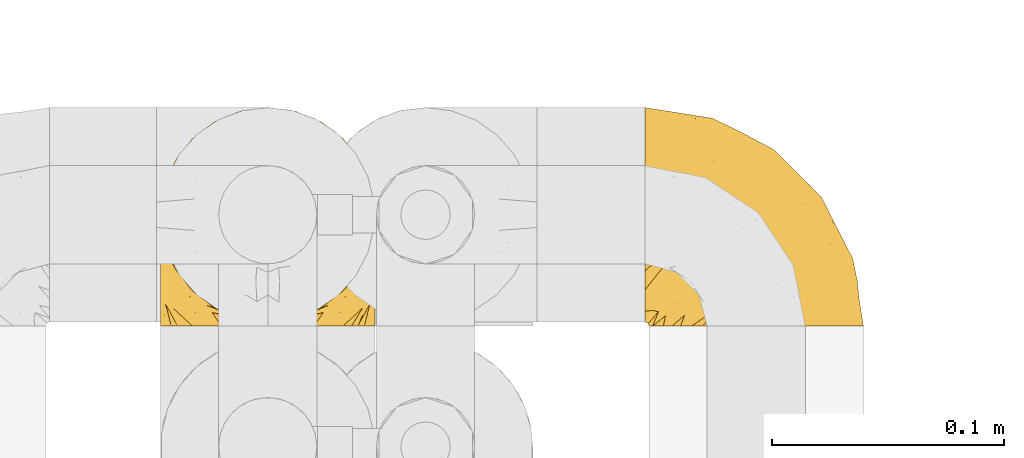
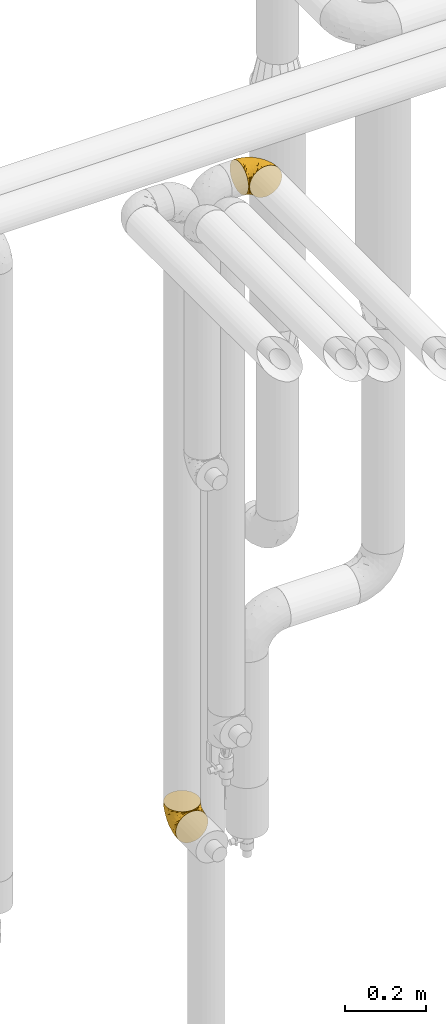
# One storey, part 312 of 827: 2 coverings.
"""IFC2X3 building model written with IfcOpenShell, lengths in millimetres."""

from ifc_helpers import new_model, entity, si_unit, converted_unit, derived_unit, direction, frame, origin, place, context, subcontext, project, spatial, faceted_brep, element, save


model = new_model("IFC2X3")

# Units and contexts
model_context = context("Model", 3, precision=0.01, world=origin(), true_north=direction((6.12303176911189e-17, 1.0)))
body_context = subcontext(model_context, "Body", "Model", "MODEL_VIEW")
ifc_project = project(units=[si_unit("LENGTHUNIT", "METRE", prefix="MILLI"), si_unit("AREAUNIT", "SQUARE_METRE"), si_unit("VOLUMEUNIT", "CUBIC_METRE"), converted_unit("PLANEANGLEUNIT", "DEGREE", entity("IfcRatioMeasure", 0.0174532925199433), si_unit("PLANEANGLEUNIT", "RADIAN"), dimensions=[0, 0, 0, 0, 0, 0, 0]), si_unit("MASSUNIT", "GRAM", prefix="KILO"), derived_unit("MASSDENSITYUNIT", [(si_unit("MASSUNIT", "GRAM", prefix="KILO"), 1), (si_unit("LENGTHUNIT", "METRE"), -3)]), derived_unit("MOMENTOFINERTIAUNIT", [(si_unit("LENGTHUNIT", "METRE"), 4)]), si_unit("TIMEUNIT", "SECOND"), si_unit("FREQUENCYUNIT", "HERTZ"), si_unit("THERMODYNAMICTEMPERATUREUNIT", "DEGREE_CELSIUS"), derived_unit("THERMALTRANSMITTANCEUNIT", [(si_unit("MASSUNIT", "GRAM", prefix="KILO"), 1), (si_unit("THERMODYNAMICTEMPERATUREUNIT", "KELVIN"), -1), (si_unit("TIMEUNIT", "SECOND"), -3)]), derived_unit("VOLUMETRICFLOWRATEUNIT", [(si_unit("LENGTHUNIT", "METRE"), 3), (si_unit("TIMEUNIT", "SECOND"), -1)]), derived_unit("MASSFLOWRATEUNIT", [(si_unit("MASSUNIT", "GRAM", prefix="KILO"), 1), (si_unit("TIMEUNIT", "SECOND"), -1)]), derived_unit("ROTATIONALFREQUENCYUNIT", [(si_unit("TIMEUNIT", "SECOND"), -1)]), si_unit("ELECTRICCURRENTUNIT", "AMPERE"), si_unit("ELECTRICVOLTAGEUNIT", "VOLT"), si_unit("POWERUNIT", "WATT"), si_unit("FORCEUNIT", "NEWTON", prefix="KILO"), si_unit("ILLUMINANCEUNIT", "LUX"), si_unit("LUMINOUSFLUXUNIT", "LUMEN"), si_unit("LUMINOUSINTENSITYUNIT", "CANDELA"), derived_unit("USERDEFINED", [(si_unit("MASSUNIT", "GRAM", prefix="KILO"), -1), (si_unit("LENGTHUNIT", "METRE"), -2), (si_unit("TIMEUNIT", "SECOND"), 3), (si_unit("LUMINOUSFLUXUNIT", "LUMEN"), 1)]), derived_unit("LINEARVELOCITYUNIT", [(si_unit("LENGTHUNIT", "METRE"), 1), (si_unit("TIMEUNIT", "SECOND"), -1)]), si_unit("PRESSUREUNIT", "PASCAL"), derived_unit("USERDEFINED", [(si_unit("LENGTHUNIT", "METRE"), -2), (si_unit("MASSUNIT", "GRAM", prefix="KILO"), 1), (si_unit("TIMEUNIT", "SECOND"), -2)]), derived_unit("LINEARFORCEUNIT", [(si_unit("MASSUNIT", "GRAM", prefix="KILO"), 1), (si_unit("LENGTHUNIT", "METRE"), 1), (si_unit("TIMEUNIT", "SECOND"), -2), (si_unit("LENGTHUNIT", "METRE"), -1)]), derived_unit("PLANARFORCEUNIT", [(si_unit("MASSUNIT", "GRAM", prefix="KILO"), 1), (si_unit("LENGTHUNIT", "METRE"), 1), (si_unit("TIMEUNIT", "SECOND"), -2), (si_unit("LENGTHUNIT", "METRE"), -2)])], contexts=[model_context])

# Site, building, storey
site_placement = place(None, origin())
site = spatial("IfcSite", under=ifc_project, at=site_placement, CompositionType="ELEMENT")
building_placement = place(site_placement, origin())
building = spatial("IfcBuilding", under=site, at=building_placement, CompositionType="ELEMENT")
storey_placement = place(building_placement, frame((0.0, 0.0, 28200.0)))
storey = spatial("IfcBuildingStorey", under=building, at=storey_placement, Name="08", CompositionType="ELEMENT", Elevation=28200.0)

# Coverings
covering_1_placement = place(storey_placement, frame((30818.01, 18391.61, 2952.2)))
element("IfcCovering", 1, at=covering_1_placement, inside=storey, Name=":ADSK_", ObjectType=":ADSK_", PredefinedType="INSULATION", context=body_context, shape_type="Brep", body=[
    faceted_brep([(1.6, 59.88, 92.84), (1.6, 69.65, 89.42), (1.6, 78.41, 83.91), (1.6, 85.72, 76.59), (1.6, 91.22, 67.83), (1.6, 94.64, 58.07), (1.6, 95.8, 47.8), (1.6, 94.64, 37.51), (1.6, 91.22, 27.74), (1.6, 85.71, 18.98), (1.6, 78.39, 11.67), (1.6, 69.63, 6.17), (1.6, 59.87, 2.75), (1.6, 49.6, 1.6), (1.6, 45.45, 2.06), (1.6, 42.38, 2.41), (1.6, 39.31, 2.75), (1.6, 34.43, 4.46), (1.6, 29.54, 6.17), (1.6, 25.16, 8.93), (1.6, 20.78, 11.68), (1.6, 17.13, 15.34), (1.6, 13.47, 19.0), (1.6, 7.97, 27.76), (1.6, 6.26, 32.64), (1.6, 4.55, 37.52), (1.6, 3.4, 47.8), (1.6, 4.55, 58.08), (1.6, 6.26, 62.96), (1.6, 7.97, 67.85), (1.6, 13.48, 76.61), (1.6, 17.14, 80.26), (1.6, 20.8, 83.92), (1.6, 25.18, 86.67), (1.6, 29.56, 89.42), (1.6, 34.44, 91.13), (1.6, 39.32, 92.84), (1.6, 42.39, 93.18), (1.6, 45.45, 93.53), (1.6, 49.6, 94.0), (3.4, 1.6, 47.8), (4.97, 1.6, 35.84), (9.58, 1.6, 24.7), (13.26, 1.6, 19.91), (16.93, 1.6, 15.13), (21.71, 1.6, 11.46), (26.5, 1.6, 7.78), (32.07, 1.6, 5.48), (37.64, 1.6, 3.17), (41.25, 1.6, 2.69), (43.34, 1.6, 2.42), (45.42, 1.6, 2.14), (49.6, 1.6, 1.6), (61.55, 1.6, 3.17), (72.7, 1.6, 7.78), (82.26, 1.6, 15.13), (89.61, 1.6, 24.7), (94.22, 1.6, 35.84), (95.8, 1.6, 47.8), (94.22, 1.6, 59.75), (89.61, 1.6, 70.9), (82.26, 1.6, 80.46), (72.7, 1.6, 87.81), (61.55, 1.6, 92.42), (49.6, 1.6, 94.0), (45.42, 1.6, 93.45), (41.25, 1.6, 92.9), (37.64, 1.6, 92.42), (32.07, 1.6, 90.11), (26.5, 1.6, 87.81), (21.71, 1.6, 84.13), (16.93, 1.6, 80.46), (13.26, 1.6, 75.68), (9.58, 1.6, 70.9), (4.97, 1.6, 59.75), (81.55, 36.81, 71.98), (90.4, 23.28, 63.6), (83.0, 45.8, 59.72), (91.18, 30.7, 47.8), (93.13, 21.2, 55.16), (94.0, 12.96, 47.8), (66.19, 66.19, 63.76), (70.92, 54.51, 72.22), (85.95, 17.98, 74.18), (49.74, 36.69, 92.52), (35.54, 35.54, 94.0), (38.14, 31.64, 94.0), (40.74, 27.75, 94.0), (43.34, 23.86, 94.0), (45.94, 19.96, 94.0), (77.59, 22.8, 82.14), (71.17, 42.67, 80.34), (65.81, 33.21, 87.52), (59.03, 59.45, 79.59), (45.85, 71.5, 78.25), (45.79, 62.66, 85.01), (41.42, 54.5, 90.25), (34.51, 47.57, 93.2), (56.04, 48.81, 87.23), (15.15, 74.98, 85.55), (56.51, 18.7, 93.0), (68.39, 15.75, 89.31), (23.33, 91.17, 61.31), (42.86, 85.28, 56.86), (39.42, 82.58, 68.34), (53.58, 75.78, 65.71), (59.17, 74.98, 56.99), (59.06, 67.27, 72.15), (22.63, 87.38, 70.34), (20.55, 82.04, 78.36), (12.96, 94.0, 47.8), (56.96, 77.8, 47.8), (67.38, 67.38, 47.8), (18.72, 56.2, 93.06), (5.33, 48.85, 94.0), (9.07, 48.11, 94.0), (11.79, 47.57, 94.0), (14.51, 47.03, 94.0), (17.24, 46.48, 94.0), (19.96, 45.94, 94.0), (21.03, 65.78, 89.88), (46.48, 17.24, 94.0), (47.03, 14.51, 94.0), (47.57, 11.79, 94.0), (48.11, 9.07, 94.0), (48.48, 7.2, 94.0), (48.85, 5.33, 94.0), (30.7, 91.18, 47.8), (23.86, 43.34, 94.0), (27.75, 40.74, 94.0), (31.64, 38.14, 94.0), (31.26, 72.73, 83.7), (77.8, 56.96, 47.8), (72.75, 62.23, 55.9), (43.83, 84.49, 47.8), (84.49, 43.83, 47.8), (14.58, 12.05, 81.75), (16.17, 18.95, 86.43), (10.82, 13.02, 79.8), (4.64, 8.34, 69.84), (7.71, 14.63, 79.5), (25.13, 11.09, 88.08), (32.66, 13.66, 91.6), (34.94, 20.08, 92.93), (36.76, 9.61, 92.43), (40.48, 9.48, 93.24), (39.25, 16.1, 93.36), (3.69, 3.42, 57.25), (13.99, 26.63, 89.41), (21.85, 33.72, 92.89), (17.93, 34.77, 92.66), (15.11, 6.75, 79.58), (21.14, 13.31, 86.51), (7.21, 19.94, 83.91), (9.47, 27.05, 88.76), (10.45, 6.04, 73.94), (32.27, 8.67, 90.94), (25.68, 26.11, 91.94), (22.18, 29.3, 91.98), (18.79, 6.32, 82.79), (10.12, 39.92, 93.16), (11.29, 34.4, 91.89), (2.87, 2.87, 47.8), (31.16, 20.92, 92.22), (12.7, 21.11, 86.29), (6.31, 27.43, 88.56), (25.62, 7.54, 87.72), (21.18, 18.45, 88.33), (28.81, 23.88, 92.18), (7.45, 7.77, 71.78), (21.14, 13.3, 9.09), (25.13, 11.09, 7.51), (18.79, 6.33, 12.8), (48.11, 9.07, 1.6), (48.85, 5.33, 1.6), (47.03, 14.51, 1.6), (47.57, 11.79, 1.6), (3.69, 3.42, 38.35), (7.44, 7.76, 23.84), (14.51, 47.03, 1.6), (11.79, 47.57, 1.6), (5.33, 48.85, 1.6), (9.07, 48.11, 1.6), (7.71, 14.62, 16.1), (9.47, 27.03, 6.84), (34.94, 20.08, 2.66), (31.16, 20.92, 3.37), (40.74, 27.75, 1.6), (38.14, 31.64, 1.6), (36.76, 9.61, 3.16), (40.48, 9.48, 2.35), (4.63, 8.33, 25.77), (15.11, 6.74, 16.02), (14.58, 12.04, 13.85), (43.34, 23.86, 1.6), (45.94, 19.96, 1.6), (39.25, 16.1, 2.23), (7.21, 19.93, 11.69), (12.69, 21.1, 9.31), (10.14, 39.92, 2.43), (21.81, 33.68, 2.71), (22.19, 29.28, 3.61), (14.0, 26.62, 6.18), (25.69, 26.08, 3.66), (16.17, 18.93, 9.17), (6.66, 27.87, 6.77), (17.92, 34.75, 2.93), (10.45, 6.04, 21.66), (31.64, 38.14, 1.6), (10.64, 12.79, 16.09), (11.31, 34.41, 3.7), (19.96, 45.94, 1.6), (23.86, 43.34, 1.6), (27.75, 40.74, 1.6), (32.66, 13.66, 3.99), (46.48, 17.24, 1.6), (32.27, 8.67, 4.65), (35.54, 35.54, 1.6), (28.77, 23.83, 3.43), (21.17, 18.43, 7.27), (23.36, 6.03, 9.46), (17.24, 46.48, 1.6), (47.58, 34.52, 2.4), (93.13, 21.2, 40.43), (77.44, 23.82, 13.57), (66.78, 41.32, 11.3), (71.68, 47.62, 18.65), (74.96, 52.66, 27.26), (81.55, 36.81, 23.61), (36.7, 49.75, 3.07), (56.9, 19.07, 2.69), (83.0, 45.8, 35.87), (90.4, 23.28, 31.99), (67.83, 21.35, 6.71), (85.95, 17.98, 21.41), (39.41, 82.57, 27.24), (23.33, 91.17, 34.26), (42.87, 85.27, 38.73), (53.92, 73.89, 26.97), (66.19, 66.19, 31.83), (64.12, 62.43, 23.4), (33.13, 63.53, 6.91), (23.1, 58.45, 3.4), (16.98, 67.16, 5.84), (55.72, 76.72, 35.73), (72.75, 62.22, 39.69), (23.77, 81.54, 17.6), (18.41, 74.8, 10.38), (43.7, 75.83, 20.6), (54.53, 41.45, 5.36), (17.73, 88.2, 24.84), (38.98, 71.6, 13.87), (50.28, 56.23, 9.06), (59.02, 59.44, 15.99)], [[[0, 1, 2, 3, 4, 5, 6, 7, 8, 9, 10, 11, 12, 13, 14, 15, 16, 17, 18, 19, 20, 21, 22, 23, 24, 25, 26, 27, 28, 29, 30, 31, 32, 33, 34, 35, 36, 37, 38, 39]], [[40, 41, 42, 43, 44, 45, 46, 47, 48, 49, 50, 51, 52, 53, 54, 55, 56, 57, 58, 59, 60, 61, 62, 63, 64, 65, 66, 67, 68, 69, 70, 71, 72, 73, 74]], [[75, 76, 77]], [[78, 79, 80]], [[77, 81, 82]], [[76, 75, 83]], [[84, 85, 86, 87, 88, 89]], [[90, 91, 92]], [[76, 60, 59]], [[93, 94, 95]], [[90, 62, 61]], [[83, 61, 60]], [[96, 97, 84]], [[98, 93, 95]], [[2, 1, 99]], [[100, 84, 89]], [[62, 101, 63]], [[4, 102, 5]], [[92, 84, 100]], [[103, 102, 104]], [[103, 105, 106]], [[93, 107, 94]], [[3, 108, 4]], [[92, 101, 90]], [[108, 3, 109]], [[102, 110, 5]], [[93, 82, 107]], [[102, 108, 104]], [[111, 106, 112]], [[109, 2, 99]], [[113, 39, 114, 115, 116, 117, 118, 119]], [[120, 0, 113]], [[100, 89, 121, 122, 123, 124, 125, 126, 64]], [[127, 102, 103]], [[97, 119, 128, 129, 130, 85]], [[99, 120, 131]], [[132, 133, 77]], [[59, 80, 79]], [[3, 2, 109]], [[98, 84, 92]], [[94, 109, 131]], [[120, 1, 0]], [[93, 91, 82]], [[104, 94, 105]], [[97, 113, 119]], [[95, 120, 96]], [[83, 90, 61]], [[91, 93, 98]], [[64, 63, 100]], [[100, 63, 101]], [[77, 76, 79]], [[133, 106, 81]], [[84, 97, 85]], [[113, 96, 120]], [[113, 97, 96]], [[39, 113, 0]], [[110, 102, 127]], [[110, 6, 5]], [[103, 111, 134, 127]], [[90, 75, 91]], [[82, 81, 107]], [[91, 75, 82]], [[77, 82, 75]], [[76, 83, 60]], [[90, 83, 75]], [[105, 107, 81]], [[94, 131, 95]], [[105, 94, 107]], [[109, 94, 104]], [[120, 95, 131]], [[98, 95, 96]], [[84, 98, 96]], [[98, 92, 91]], [[106, 105, 81]], [[103, 104, 105]], [[133, 132, 112]], [[103, 106, 111]], [[77, 78, 135, 132]], [[106, 133, 112]], [[77, 133, 81]], [[120, 99, 1]], [[109, 99, 131]], [[59, 58, 80]], [[59, 79, 76]], [[90, 101, 62]], [[100, 101, 92]], [[4, 108, 102]], [[109, 104, 108]], [[78, 77, 79]], [[136, 137, 138]], [[29, 139, 140]], [[141, 142, 143]], [[144, 145, 121]], [[146, 89, 88]], [[147, 139, 27]], [[148, 149, 150]], [[136, 151, 152]], [[147, 40, 74]], [[26, 147, 27]], [[153, 148, 154]], [[35, 116, 36]], [[73, 151, 155]], [[114, 39, 38, 37, 36, 116, 115]], [[146, 156, 144]], [[157, 85, 130]], [[158, 149, 148]], [[151, 159, 152]], [[117, 35, 160]], [[31, 153, 154]], [[155, 74, 73]], [[161, 128, 119]], [[66, 65, 64, 126, 125, 124, 123, 122, 67]], [[162, 147, 26]], [[29, 140, 30]], [[149, 129, 150]], [[139, 29, 28, 27]], [[68, 144, 69]], [[129, 128, 150]], [[163, 87, 86]], [[130, 129, 149]], [[122, 145, 67]], [[153, 164, 148]], [[161, 119, 160]], [[165, 32, 154]], [[150, 154, 148]], [[128, 161, 150]], [[32, 165, 33]], [[145, 144, 68]], [[89, 146, 144]], [[87, 163, 143]], [[166, 156, 142]], [[88, 87, 143]], [[161, 154, 150]], [[154, 32, 31]], [[31, 30, 153]], [[30, 140, 153]], [[164, 153, 140]], [[140, 137, 164]], [[158, 148, 164]], [[157, 130, 158]], [[164, 137, 158]], [[158, 137, 157]], [[167, 137, 136]], [[168, 85, 157]], [[152, 168, 167]], [[167, 168, 157]], [[163, 152, 141]], [[151, 73, 72]], [[159, 72, 71]], [[88, 142, 146]], [[144, 156, 69]], [[146, 142, 156]], [[70, 166, 71]], [[142, 141, 166]], [[70, 69, 156]], [[141, 159, 71]], [[167, 136, 152]], [[138, 137, 140]], [[155, 136, 169]], [[136, 155, 151]], [[74, 155, 169]], [[152, 159, 141]], [[151, 72, 159]], [[168, 152, 163]], [[137, 167, 157]], [[163, 86, 168]], [[85, 168, 86]], [[116, 35, 117]], [[130, 149, 158]], [[67, 145, 68]], [[121, 89, 144]], [[145, 122, 121]], [[40, 147, 162]], [[169, 147, 74]], [[160, 35, 34]], [[161, 160, 34]], [[160, 119, 118, 117]], [[139, 147, 169]], [[139, 169, 138]], [[161, 34, 33]], [[141, 143, 163]], [[88, 143, 142]], [[71, 166, 141]], [[156, 166, 70]], [[139, 138, 140]], [[169, 136, 138]], [[154, 161, 165]], [[161, 33, 165]], [[170, 171, 172]], [[173, 174, 52, 51, 50, 49, 48, 175, 176]], [[177, 178, 41]], [[179, 17, 180]], [[14, 13, 181, 182, 180, 16, 15]], [[183, 23, 22]], [[21, 20, 184]], [[185, 186, 187]], [[186, 188, 187]], [[43, 172, 44]], [[189, 190, 47]], [[25, 24, 23, 191]], [[170, 192, 193]], [[40, 162, 177]], [[194, 195, 196]], [[26, 25, 177]], [[197, 198, 183]], [[199, 17, 179]], [[47, 46, 189]], [[200, 201, 202]], [[201, 203, 204]], [[205, 206, 184]], [[207, 41, 178]], [[18, 17, 199]], [[16, 180, 17]], [[202, 201, 198]], [[208, 201, 200]], [[162, 26, 177]], [[48, 47, 190]], [[196, 195, 189]], [[197, 184, 202]], [[204, 193, 209]], [[210, 211, 212]], [[206, 212, 213]], [[205, 19, 210]], [[184, 206, 202]], [[210, 212, 206]], [[185, 194, 214]], [[189, 215, 190]], [[216, 45, 214]], [[186, 171, 170]], [[189, 216, 196]], [[197, 22, 21]], [[194, 185, 187]], [[197, 183, 22]], [[184, 197, 21]], [[197, 202, 198]], [[206, 200, 202]], [[204, 183, 198]], [[201, 208, 203]], [[203, 208, 217]], [[204, 198, 201]], [[217, 188, 218]], [[193, 219, 170]], [[171, 186, 185]], [[170, 218, 186]], [[170, 219, 218]], [[42, 207, 192]], [[171, 220, 172]], [[216, 189, 46]], [[214, 194, 196]], [[44, 220, 45]], [[214, 196, 216]], [[216, 46, 45]], [[214, 45, 220]], [[192, 43, 42]], [[204, 203, 219]], [[207, 193, 192]], [[209, 193, 178]], [[41, 207, 42]], [[193, 207, 178]], [[43, 192, 172]], [[170, 172, 192]], [[204, 219, 193]], [[219, 203, 218]], [[217, 218, 203]], [[188, 186, 218]], [[206, 213, 200]], [[208, 200, 213]], [[199, 210, 18]], [[215, 189, 195]], [[215, 175, 190]], [[175, 48, 190]], [[199, 179, 221, 211]], [[210, 199, 211]], [[25, 191, 177]], [[40, 177, 41]], [[183, 209, 191]], [[183, 191, 23]], [[191, 178, 177]], [[205, 20, 19]], [[19, 18, 210]], [[171, 185, 214]], [[172, 220, 44]], [[214, 220, 171]], [[191, 209, 178]], [[204, 209, 183]], [[206, 205, 210]], [[20, 205, 184]], [[222, 195, 194, 187, 188, 217]], [[57, 223, 80]], [[224, 225, 226]], [[226, 227, 228]], [[229, 217, 208, 213, 212, 211]], [[230, 52, 174, 173, 176, 175, 215, 195]], [[231, 232, 228]], [[231, 78, 223]], [[223, 57, 232]], [[224, 233, 225]], [[233, 54, 53]], [[234, 232, 56]], [[56, 55, 234]], [[234, 224, 228]], [[235, 236, 237]], [[224, 55, 54]], [[238, 239, 240]], [[52, 230, 53]], [[241, 242, 243]], [[239, 244, 245]], [[13, 12, 242]], [[236, 8, 7]], [[9, 246, 10]], [[10, 247, 11]], [[238, 248, 235]], [[222, 229, 249]], [[242, 211, 221, 179, 180, 182, 181, 13]], [[233, 53, 230]], [[111, 112, 244]], [[250, 8, 236]], [[247, 251, 241]], [[8, 250, 9]], [[127, 236, 110]], [[249, 229, 252]], [[247, 10, 246]], [[235, 246, 250]], [[236, 7, 110]], [[235, 244, 238]], [[237, 236, 127]], [[243, 11, 247]], [[252, 229, 241]], [[56, 232, 57]], [[222, 230, 195]], [[225, 249, 252]], [[249, 233, 230]], [[54, 233, 224]], [[231, 228, 227]], [[245, 132, 231]], [[249, 225, 233]], [[226, 225, 253]], [[235, 250, 236]], [[246, 9, 250]], [[251, 247, 246]], [[243, 247, 241]], [[248, 246, 235]], [[252, 251, 253]], [[229, 222, 217]], [[230, 222, 249]], [[7, 6, 110]], [[237, 127, 134, 111]], [[238, 244, 239]], [[224, 234, 55]], [[232, 234, 228]], [[242, 241, 229]], [[12, 11, 243]], [[211, 242, 229]], [[12, 243, 242]], [[80, 223, 78]], [[80, 58, 57]], [[231, 223, 232]], [[227, 240, 239]], [[224, 226, 228]], [[240, 226, 253]], [[227, 239, 245]], [[226, 240, 227]], [[251, 248, 253]], [[240, 253, 248]], [[244, 235, 237]], [[237, 111, 244]], [[132, 245, 112]], [[112, 245, 244]], [[135, 78, 231, 132]], [[227, 245, 231]], [[248, 238, 240]], [[246, 248, 251]], [[251, 252, 241]], [[225, 252, 253]]]),
])
covering_2_placement = place(storey_placement, frame((30609.25, 18391.61, 1082.65)))
element("IfcCovering", 2, at=covering_2_placement, inside=storey, Name=":ADSK_", ObjectType=":ADSK_", PredefinedType="INSULATION", context=body_context, shape_type="Brep", body=[
    faceted_brep([(11.68, 1.6, 18.98), (19.0, 1.6, 11.67), (27.76, 1.6, 6.17), (37.52, 1.6, 2.75), (47.8, 1.6, 1.6), (58.08, 1.6, 2.75), (67.85, 1.6, 6.17), (76.61, 1.6, 11.68), (83.92, 1.6, 19.0), (89.42, 1.6, 27.76), (92.84, 1.6, 37.52), (94.0, 1.6, 47.8), (93.53, 1.6, 51.94), (93.18, 1.6, 55.01), (92.84, 1.6, 58.08), (91.13, 1.6, 62.96), (89.42, 1.6, 67.85), (86.66, 1.6, 72.23), (83.91, 1.6, 76.61), (80.25, 1.6, 80.26), (76.59, 1.6, 83.92), (67.83, 1.6, 89.42), (62.95, 1.6, 91.13), (58.07, 1.6, 92.84), (47.8, 1.6, 94.0), (37.51, 1.6, 92.84), (32.63, 1.6, 91.13), (27.74, 1.6, 89.42), (18.98, 1.6, 83.91), (15.33, 1.6, 80.25), (11.67, 1.6, 76.59), (8.92, 1.6, 72.21), (6.17, 1.6, 67.83), (4.46, 1.6, 62.95), (2.75, 1.6, 58.07), (2.41, 1.6, 55.0), (2.06, 1.6, 51.94), (1.6, 1.6, 47.8), (2.75, 1.6, 37.51), (6.17, 1.6, 27.74), (47.8, 3.4, 95.8), (59.75, 4.97, 95.8), (70.9, 9.58, 95.8), (75.68, 13.26, 95.8), (80.46, 16.93, 95.8), (84.13, 21.71, 95.8), (87.81, 26.5, 95.8), (90.11, 32.07, 95.8), (92.42, 37.64, 95.8), (92.9, 41.25, 95.8), (93.17, 43.34, 95.8), (93.45, 45.42, 95.8), (94.0, 49.6, 95.8), (92.42, 61.55, 95.8), (87.81, 72.7, 95.8), (80.46, 82.26, 95.8), (70.9, 89.61, 95.8), (59.75, 94.22, 95.8), (47.8, 95.8, 95.8), (35.84, 94.22, 95.8), (24.7, 89.61, 95.8), (15.13, 82.26, 95.8), (7.78, 72.7, 95.8), (3.17, 61.55, 95.8), (1.6, 49.6, 95.8), (2.14, 45.42, 95.8), (2.69, 41.25, 95.8), (3.17, 37.64, 95.8), (5.48, 32.07, 95.8), (7.78, 26.5, 95.8), (11.46, 21.71, 95.8), (15.13, 16.93, 95.8), (19.91, 13.26, 95.8), (24.7, 9.58, 95.8), (35.84, 4.97, 95.8), (23.61, 81.55, 60.58), (31.99, 90.4, 74.11), (35.87, 83.0, 51.59), (47.8, 91.18, 66.69), (40.43, 93.13, 76.19), (47.8, 94.0, 84.43), (31.83, 66.19, 31.2), (23.37, 70.92, 42.88), (21.41, 85.95, 79.41), (3.07, 49.74, 60.7), (1.6, 35.54, 61.85), (1.6, 38.14, 65.75), (1.6, 40.74, 69.64), (1.6, 43.34, 73.53), (1.6, 45.94, 77.43), (13.45, 77.59, 74.59), (15.25, 71.17, 54.72), (8.07, 65.81, 64.18), (16.0, 59.03, 37.94), (17.34, 45.85, 25.89), (10.58, 45.79, 34.73), (5.34, 41.42, 42.89), (2.39, 34.51, 49.83), (8.36, 56.04, 48.58), (10.04, 15.15, 22.41), (2.59, 56.51, 78.69), (6.28, 68.39, 81.64), (34.28, 23.33, 6.22), (38.73, 42.86, 12.11), (27.25, 39.42, 14.81), (29.88, 53.58, 21.61), (38.6, 59.17, 22.41), (23.44, 59.06, 30.12), (25.25, 22.63, 10.01), (17.23, 20.55, 15.36), (47.8, 12.96, 3.39), (47.8, 56.96, 19.59), (47.8, 67.38, 30.01), (2.53, 18.72, 41.19), (1.6, 5.33, 48.54), (1.6, 9.07, 49.28), (1.6, 11.79, 49.82), (1.6, 14.51, 50.37), (1.6, 17.24, 50.91), (1.6, 19.96, 51.45), (5.71, 21.03, 31.61), (1.6, 46.48, 80.15), (1.6, 47.03, 82.88), (1.6, 47.57, 85.6), (1.6, 48.11, 88.32), (1.6, 48.48, 90.19), (1.6, 48.85, 92.06), (47.8, 30.7, 6.21), (1.6, 23.86, 54.05), (1.6, 27.75, 56.65), (1.6, 31.64, 59.25), (11.89, 31.26, 24.66), (47.8, 77.8, 40.43), (39.69, 72.75, 35.17), (47.8, 43.83, 12.9), (47.8, 84.49, 53.56), (13.84, 14.58, 85.34), (9.16, 16.17, 78.44), (15.79, 10.82, 84.37), (25.75, 4.64, 89.05), (16.09, 7.71, 82.76), (7.51, 25.13, 86.31), (3.99, 32.66, 83.73), (2.66, 34.94, 77.31), (3.16, 36.76, 87.78), (2.35, 40.48, 87.91), (2.23, 39.25, 81.29), (38.35, 3.69, 93.97), (6.18, 13.99, 70.76), (2.7, 21.85, 63.67), (2.93, 17.93, 62.62), (16.01, 15.11, 90.64), (9.08, 21.14, 84.08), (11.68, 7.21, 77.45), (6.83, 9.47, 70.34), (4.65, 32.27, 88.72), (3.65, 25.68, 71.28), (3.61, 22.18, 68.09), (12.8, 18.79, 91.07), (2.43, 10.12, 57.47), (21.65, 10.45, 91.35), (3.7, 11.29, 62.99), (47.8, 2.87, 94.52), (3.37, 31.16, 76.47), (9.3, 12.7, 76.28), (7.03, 6.31, 69.96), (7.87, 25.62, 89.86), (7.26, 21.18, 78.94), (3.41, 28.81, 73.51), (23.81, 7.45, 89.62), (86.5, 21.14, 84.09), (88.08, 25.13, 86.3), (82.79, 18.79, 91.06), (94.0, 48.85, 92.06), (94.0, 47.03, 82.88), (94.0, 47.57, 85.6), (94.0, 48.11, 88.32), (57.24, 3.69, 93.97), (71.76, 7.44, 89.63), (94.0, 14.51, 50.37), (94.0, 11.79, 49.82), (94.0, 5.33, 48.54), (94.0, 9.07, 49.28), (79.49, 7.71, 82.77), (88.75, 9.47, 70.36), (92.93, 34.94, 77.31), (92.22, 31.16, 76.47), (94.0, 40.74, 69.64), (94.0, 38.14, 65.75), (92.43, 36.76, 87.78), (93.24, 40.48, 87.91), (69.82, 4.63, 89.06), (79.57, 15.11, 90.65), (81.74, 14.58, 85.35), (94.0, 43.34, 73.53), (94.0, 45.94, 77.43), (93.36, 39.25, 81.29), (83.9, 7.21, 77.46), (86.28, 12.69, 76.29), (93.16, 10.14, 57.47), (92.88, 21.81, 63.71), (91.98, 22.19, 68.11), (89.41, 14.0, 70.77), (91.93, 25.69, 71.31), (86.42, 16.17, 78.46), (88.82, 6.66, 69.52), (92.66, 17.92, 62.64), (73.93, 10.45, 91.35), (94.0, 31.64, 59.25), (79.5, 10.64, 84.6), (91.89, 11.31, 62.98), (94.0, 19.96, 51.45), (94.0, 23.86, 54.05), (94.0, 27.75, 56.65), (91.6, 32.66, 83.73), (94.0, 46.48, 80.15), (90.94, 32.27, 88.72), (94.0, 35.54, 61.85), (92.16, 28.77, 73.56), (88.32, 21.17, 78.96), (86.13, 23.36, 91.36), (94.0, 17.24, 50.91), (93.2, 47.58, 62.87), (55.16, 93.13, 76.19), (82.02, 77.44, 73.57), (84.29, 66.78, 56.07), (76.94, 71.68, 49.77), (68.33, 74.96, 44.73), (71.98, 81.55, 60.58), (92.52, 36.7, 47.64), (92.9, 56.9, 78.32), (59.72, 83.0, 51.59), (63.6, 90.4, 74.11), (88.89, 67.83, 76.04), (74.18, 85.95, 79.41), (68.35, 39.41, 14.82), (61.33, 23.33, 6.22), (56.86, 42.87, 12.12), (68.62, 53.92, 23.51), (63.76, 66.19, 31.2), (72.19, 64.12, 34.96), (88.69, 33.13, 33.86), (92.19, 23.1, 38.94), (89.75, 16.98, 30.23), (59.86, 55.72, 20.67), (55.9, 72.75, 35.17), (77.99, 23.77, 15.85), (85.21, 18.41, 22.59), (74.99, 43.7, 21.56), (90.23, 54.53, 55.94), (70.75, 17.73, 9.19), (81.72, 38.98, 25.79), (86.53, 50.28, 41.16), (79.6, 59.02, 37.95)], [[[0, 1, 2, 3, 4, 5, 6, 7, 8, 9, 10, 11, 12, 13, 14, 15, 16, 17, 18, 19, 20, 21, 22, 23, 24, 25, 26, 27, 28, 29, 30, 31, 32, 33, 34, 35, 36, 37, 38, 39]], [[40, 41, 42, 43, 44, 45, 46, 47, 48, 49, 50, 51, 52, 53, 54, 55, 56, 57, 58, 59, 60, 61, 62, 63, 64, 65, 66, 67, 68, 69, 70, 71, 72, 73, 74]], [[75, 76, 77]], [[78, 79, 80]], [[77, 81, 82]], [[76, 75, 83]], [[84, 85, 86, 87, 88, 89]], [[90, 91, 92]], [[76, 60, 59]], [[93, 94, 95]], [[90, 62, 61]], [[83, 61, 60]], [[96, 97, 84]], [[98, 93, 95]], [[0, 39, 99]], [[100, 84, 89]], [[62, 101, 63]], [[2, 102, 3]], [[92, 84, 100]], [[103, 102, 104]], [[103, 105, 106]], [[93, 107, 94]], [[1, 108, 2]], [[92, 101, 90]], [[108, 1, 109]], [[102, 110, 3]], [[93, 82, 107]], [[102, 108, 104]], [[111, 106, 112]], [[109, 0, 99]], [[113, 37, 114, 115, 116, 117, 118, 119]], [[120, 38, 113]], [[100, 89, 121, 122, 123, 124, 125, 126, 64]], [[127, 102, 103]], [[97, 119, 128, 129, 130, 85]], [[99, 120, 131]], [[132, 133, 77]], [[59, 80, 79]], [[1, 0, 109]], [[98, 84, 92]], [[94, 109, 131]], [[120, 39, 38]], [[93, 91, 82]], [[104, 94, 105]], [[97, 113, 119]], [[95, 120, 96]], [[83, 90, 61]], [[91, 93, 98]], [[64, 63, 100]], [[100, 63, 101]], [[77, 76, 79]], [[133, 106, 81]], [[84, 97, 85]], [[113, 96, 120]], [[113, 97, 96]], [[37, 113, 38]], [[110, 102, 127]], [[110, 4, 3]], [[103, 111, 134, 127]], [[90, 75, 91]], [[82, 81, 107]], [[91, 75, 82]], [[77, 82, 75]], [[76, 83, 60]], [[90, 83, 75]], [[105, 107, 81]], [[94, 131, 95]], [[105, 94, 107]], [[109, 94, 104]], [[120, 95, 131]], [[98, 95, 96]], [[84, 98, 96]], [[98, 92, 91]], [[106, 105, 81]], [[103, 104, 105]], [[133, 132, 112]], [[103, 106, 111]], [[77, 78, 135, 132]], [[81, 77, 133]], [[106, 133, 112]], [[120, 99, 39]], [[109, 99, 131]], [[59, 58, 80]], [[59, 79, 76]], [[90, 101, 62]], [[100, 101, 92]], [[2, 108, 102]], [[109, 104, 108]], [[78, 77, 79]], [[136, 137, 138]], [[27, 139, 140]], [[141, 142, 143]], [[144, 145, 121]], [[146, 89, 88]], [[147, 139, 25]], [[148, 149, 150]], [[136, 151, 152]], [[147, 40, 74]], [[24, 147, 25]], [[153, 148, 154]], [[33, 116, 34]], [[73, 72, 151]], [[114, 37, 36, 35, 34, 116, 115]], [[146, 155, 144]], [[156, 85, 130]], [[157, 149, 148]], [[151, 158, 152]], [[117, 33, 159]], [[29, 153, 154]], [[160, 74, 73]], [[161, 128, 119]], [[66, 65, 64, 126, 125, 124, 123, 122, 67]], [[162, 147, 24]], [[27, 140, 28]], [[149, 129, 150]], [[139, 27, 26, 25]], [[68, 144, 69]], [[129, 128, 150]], [[163, 87, 86]], [[130, 129, 149]], [[122, 145, 67]], [[153, 164, 148]], [[161, 119, 159]], [[165, 30, 154]], [[150, 154, 148]], [[128, 161, 150]], [[30, 165, 31]], [[145, 144, 68]], [[89, 146, 144]], [[87, 163, 143]], [[166, 155, 142]], [[88, 87, 143]], [[161, 154, 150]], [[154, 30, 29]], [[29, 28, 153]], [[28, 140, 153]], [[164, 153, 140]], [[140, 137, 164]], [[157, 148, 164]], [[156, 130, 157]], [[164, 137, 157]], [[157, 137, 156]], [[167, 137, 136]], [[168, 85, 156]], [[152, 168, 167]], [[167, 168, 156]], [[163, 152, 141]], [[71, 158, 72]], [[152, 167, 136]], [[88, 142, 146]], [[144, 155, 69]], [[146, 142, 155]], [[70, 166, 71]], [[142, 141, 166]], [[70, 69, 155]], [[141, 158, 71]], [[160, 73, 151]], [[138, 137, 140]], [[160, 136, 169]], [[136, 160, 151]], [[74, 160, 169]], [[152, 158, 141]], [[151, 72, 158]], [[168, 152, 163]], [[137, 167, 156]], [[163, 86, 168]], [[85, 168, 86]], [[116, 33, 117]], [[130, 149, 157]], [[67, 145, 68]], [[121, 89, 144]], [[145, 122, 121]], [[40, 147, 162]], [[169, 147, 74]], [[159, 33, 32]], [[161, 159, 32]], [[159, 119, 118, 117]], [[139, 147, 169]], [[139, 169, 138]], [[161, 32, 31]], [[141, 143, 163]], [[88, 143, 142]], [[71, 166, 141]], [[155, 166, 70]], [[139, 138, 140]], [[169, 136, 138]], [[154, 161, 165]], [[161, 31, 165]], [[170, 171, 172]], [[173, 52, 51, 50, 49, 48, 174, 175, 176]], [[177, 178, 41]], [[179, 15, 180]], [[12, 11, 181, 182, 180, 14, 13]], [[183, 21, 20]], [[19, 18, 184]], [[185, 186, 187]], [[186, 188, 187]], [[43, 172, 44]], [[189, 190, 47]], [[23, 22, 21, 191]], [[170, 192, 193]], [[40, 162, 177]], [[194, 195, 196]], [[24, 23, 177]], [[197, 198, 183]], [[199, 15, 179]], [[47, 46, 189]], [[200, 201, 202]], [[201, 203, 204]], [[205, 206, 184]], [[207, 41, 178]], [[16, 15, 199]], [[14, 180, 15]], [[202, 201, 198]], [[208, 201, 200]], [[162, 24, 177]], [[48, 47, 190]], [[196, 195, 189]], [[197, 184, 202]], [[204, 193, 209]], [[210, 211, 212]], [[206, 212, 213]], [[205, 17, 210]], [[184, 206, 202]], [[210, 212, 206]], [[185, 194, 214]], [[189, 215, 190]], [[216, 45, 214]], [[186, 171, 170]], [[189, 216, 196]], [[197, 20, 19]], [[194, 185, 187]], [[197, 183, 20]], [[184, 197, 19]], [[197, 202, 198]], [[206, 200, 202]], [[204, 183, 198]], [[201, 208, 203]], [[203, 208, 217]], [[204, 198, 201]], [[217, 188, 218]], [[193, 219, 170]], [[171, 186, 185]], [[170, 218, 186]], [[170, 219, 218]], [[42, 207, 192]], [[171, 220, 172]], [[216, 189, 46]], [[214, 194, 196]], [[44, 220, 45]], [[214, 196, 216]], [[216, 46, 45]], [[214, 45, 220]], [[192, 43, 42]], [[204, 203, 219]], [[207, 193, 192]], [[209, 193, 178]], [[41, 207, 42]], [[193, 207, 178]], [[43, 192, 172]], [[170, 172, 192]], [[204, 219, 193]], [[219, 203, 218]], [[217, 218, 203]], [[188, 186, 218]], [[206, 213, 200]], [[208, 200, 213]], [[199, 210, 16]], [[215, 189, 195]], [[215, 174, 190]], [[174, 48, 190]], [[199, 179, 221, 211]], [[210, 199, 211]], [[23, 191, 177]], [[40, 177, 41]], [[183, 209, 191]], [[183, 191, 21]], [[191, 178, 177]], [[205, 18, 17]], [[17, 16, 210]], [[171, 185, 214]], [[172, 220, 44]], [[214, 220, 171]], [[191, 209, 178]], [[204, 209, 183]], [[206, 205, 210]], [[18, 205, 184]], [[222, 195, 194, 187, 188, 217]], [[57, 223, 80]], [[224, 225, 226]], [[226, 227, 228]], [[229, 217, 208, 213, 212, 211]], [[230, 52, 173, 176, 175, 174, 215, 195]], [[231, 232, 228]], [[231, 78, 223]], [[223, 57, 232]], [[224, 233, 225]], [[233, 54, 53]], [[234, 232, 56]], [[56, 55, 234]], [[234, 224, 228]], [[235, 236, 237]], [[224, 55, 54]], [[238, 239, 240]], [[52, 230, 53]], [[241, 242, 243]], [[239, 244, 245]], [[11, 10, 242]], [[236, 6, 5]], [[7, 246, 8]], [[8, 247, 9]], [[238, 248, 235]], [[222, 229, 249]], [[242, 211, 221, 179, 180, 182, 181, 11]], [[233, 53, 230]], [[111, 112, 244]], [[250, 6, 236]], [[247, 251, 241]], [[6, 250, 7]], [[127, 236, 110]], [[249, 229, 252]], [[247, 8, 246]], [[235, 246, 250]], [[236, 5, 110]], [[235, 244, 238]], [[237, 236, 127]], [[243, 9, 247]], [[252, 229, 241]], [[56, 232, 57]], [[222, 230, 195]], [[225, 249, 252]], [[249, 233, 230]], [[54, 233, 224]], [[231, 228, 227]], [[245, 132, 231]], [[249, 225, 233]], [[226, 225, 253]], [[235, 250, 236]], [[246, 7, 250]], [[251, 247, 246]], [[243, 247, 241]], [[248, 246, 235]], [[252, 251, 253]], [[229, 222, 217]], [[230, 222, 249]], [[5, 4, 110]], [[237, 127, 134, 111]], [[238, 244, 239]], [[224, 234, 55]], [[232, 234, 228]], [[242, 241, 229]], [[10, 9, 243]], [[211, 242, 229]], [[10, 243, 242]], [[80, 223, 78]], [[80, 58, 57]], [[231, 223, 232]], [[227, 240, 239]], [[224, 226, 228]], [[240, 226, 253]], [[227, 239, 245]], [[226, 240, 227]], [[251, 248, 253]], [[240, 253, 248]], [[244, 235, 237]], [[237, 111, 244]], [[132, 245, 112]], [[112, 245, 244]], [[135, 78, 231, 132]], [[227, 245, 231]], [[248, 238, 240]], [[246, 248, 251]], [[251, 252, 241]], [[225, 252, 253]]]),
])

save(model, "model.ifc")
